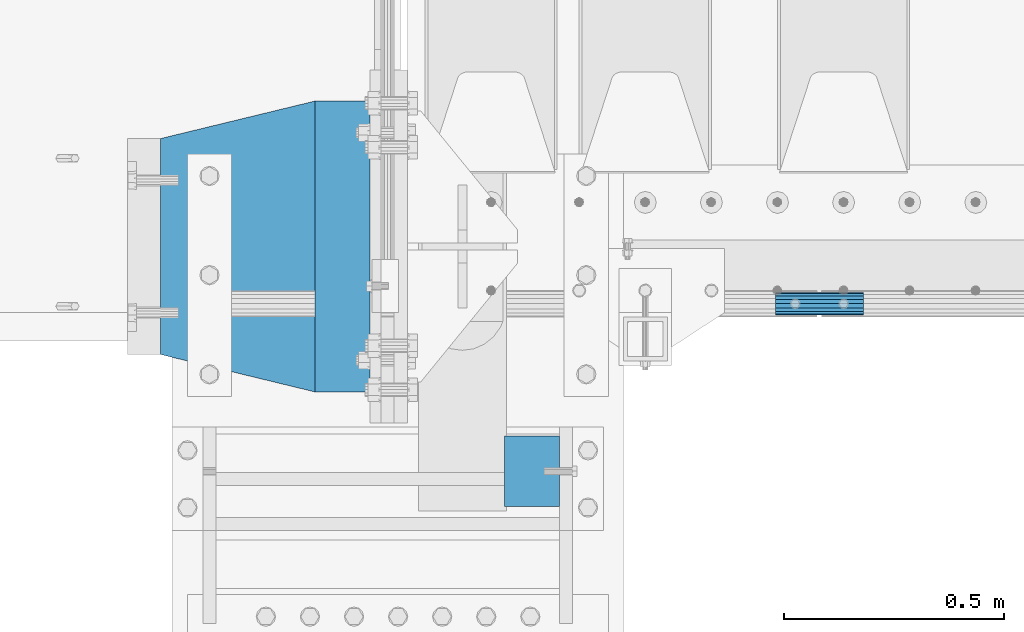
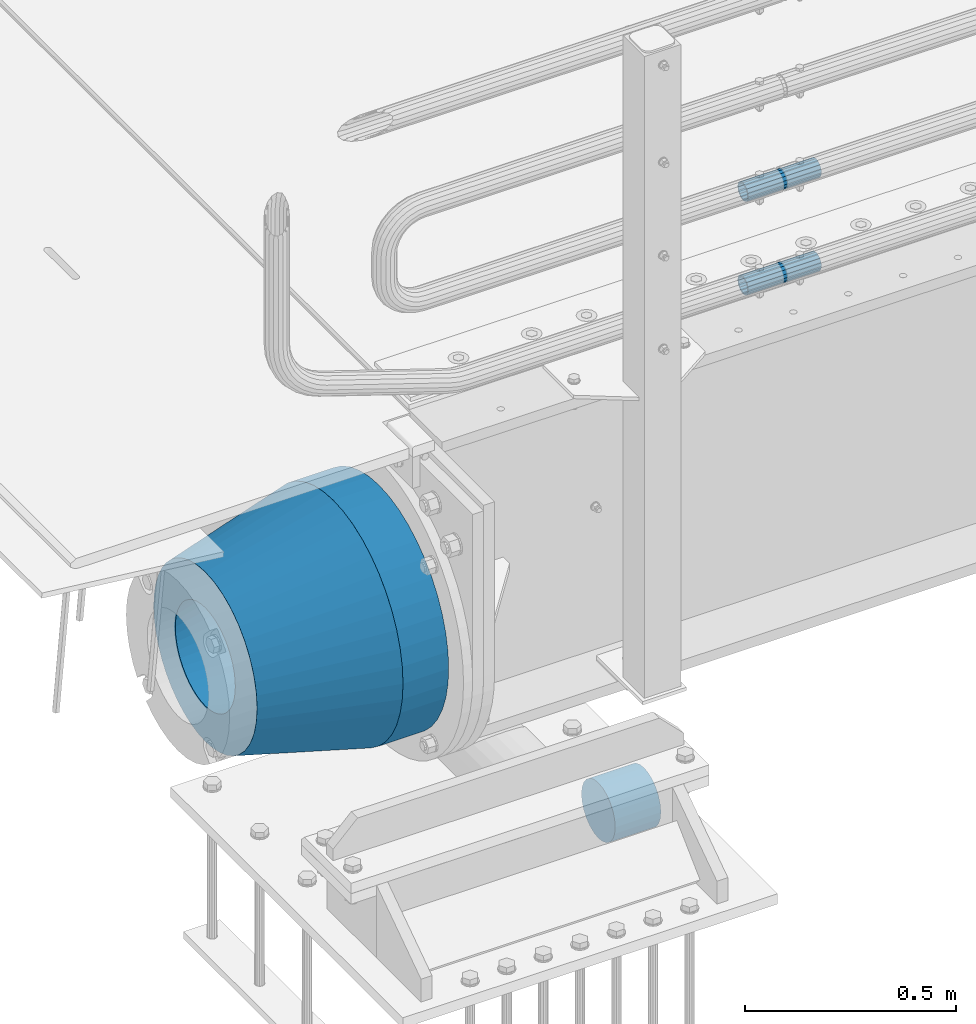
# One storey, part 131 of 240: 5 beams.
"""IFC2X3 building model written with IfcOpenShell, lengths in millimetres."""

from ifc_helpers import new_model, si_unit, frame, origin_with_axes, place, context, subcontext, project, spatial, faceted_brep, material, type_object, element, save


model = new_model("IFC2X3")

# Units and contexts
model_context = context("Model", 3, precision=1e-05, world=origin_with_axes())
body_context = subcontext(model_context, "Body", "Model", "MODEL_VIEW")
ifc_project = project(units=[si_unit("LENGTHUNIT", "METRE", prefix="MILLI"), si_unit("AREAUNIT", "SQUARE_METRE"), si_unit("VOLUMEUNIT", "CUBIC_METRE"), si_unit("MASSUNIT", "GRAM", prefix="KILO"), si_unit("TIMEUNIT", "SECOND"), si_unit("PLANEANGLEUNIT", "RADIAN"), si_unit("SOLIDANGLEUNIT", "STERADIAN"), si_unit("THERMODYNAMICTEMPERATUREUNIT", "DEGREE_CELSIUS"), si_unit("LUMINOUSINTENSITYUNIT", "LUMEN")], contexts=[model_context])

# Site, building, storey
site_placement = place(None, origin_with_axes())
site = spatial("IfcSite", under=ifc_project, at=site_placement, CompositionType="ELEMENT")
building_placement = place(site_placement, origin_with_axes())
building = spatial("IfcBuilding", under=site, at=building_placement, Name="Standard", CompositionType="ELEMENT")
storey_placement = place(building_placement, origin_with_axes())
storey = spatial("IfcBuildingStorey", under=building, at=storey_placement, Name="Undefined", CompositionType="ELEMENT", Elevation=0.0)

# Beams
ifc_material_1 = material()
beam_type_1 = type_object("IfcBeamType", PredefinedType="NOTDEFINED")
beam_1_placement = place(storey_placement, frame((42680.0000000009, 23490.000000001, -923.000000000004), z_axis=(0.0, 0.0, -1.0), x_axis=(1.0, 0.0, 0.0)))
element("IfcBeam", 1, at=beam_1_placement, inside=storey, type_object=beam_type_1, material=ifc_material_1, context=body_context, shape_type="Brep", body=[
    faceted_brep([(0.0, -80.0, 0.0), (0.0, -77.2740661031239, -20.7055236082017), (125.0, -77.2740661031239, -20.7055236082017), (125.0, -80.0, 0.0), (0.0, -69.2820323027554, -40.0), (125.0, -69.2820323027554, -40.0), (0.0, -56.5685424949224, -56.5685424949238), (125.0, -56.5685424949224, -56.5685424949238), (0.0, -40.0, -69.2820323027552), (125.0, -40.0, -69.2820323027552), (0.0, -20.7055236082015, -77.2740661031255), (125.0, -20.7055236082015, -77.2740661031255), (0.0, 0.0, -80.0), (125.0, 0.0, -80.0), (0.0, 20.7055236082015, -77.2740661031255), (125.0, 20.7055236082015, -77.2740661031255), (0.0, 40.0, -69.2820323027551), (125.0, 40.0, -69.2820323027551), (0.0, 56.5685424949224, -56.5685424949238), (125.0, 56.5685424949224, -56.5685424949238), (0.0, 69.2820323027554, -40.0), (125.0, 69.2820323027554, -40.0), (0.0, 77.2740661031239, -20.7055236082016), (125.0, 77.2740661031239, -20.7055236082016), (0.0, 80.0, 0.0), (125.0, 80.0, 0.0), (0.0, 77.2740661031239, 20.7055236082017), (125.0, 77.2740661031239, 20.7055236082017), (0.0, 69.2820323027554, 40.0), (125.0, 69.2820323027554, 40.0), (0.0, 56.5685424949224, 56.5685424949238), (125.0, 56.5685424949224, 56.5685424949238), (0.0, 40.0, 69.2820323027551), (125.0, 40.0, 69.2820323027551), (0.0, 20.7055236082015, 77.2740661031255), (125.0, 20.7055236082015, 77.2740661031255), (0.0, 0.0, 80.0), (125.0, 0.0, 80.0), (0.0, -20.7055236082015, 77.2740661031255), (125.0, -20.7055236082015, 77.2740661031255), (0.0, -40.0, 69.2820323027551), (125.0, -40.0, 69.2820323027551), (0.0, -56.5685424949224, 56.5685424949238), (125.0, -56.5685424949224, 56.5685424949238), (0.0, -69.2820323027554, 40.0), (125.0, -69.2820323027554, 40.0), (0.0, -77.2740661031239, 20.7055236082017), (125.0, -77.2740661031239, 20.7055236082017)], [[[0, 1, 2, 3]], [[1, 4, 5, 2]], [[4, 6, 7, 5]], [[6, 8, 9, 7]], [[8, 10, 11, 9]], [[10, 12, 13, 11]], [[12, 14, 15, 13]], [[14, 16, 17, 15]], [[16, 18, 19, 17]], [[18, 20, 21, 19]], [[20, 22, 23, 21]], [[22, 24, 25, 23]], [[24, 26, 27, 25]], [[26, 28, 29, 27]], [[28, 30, 31, 29]], [[30, 32, 33, 31]], [[32, 34, 35, 33]], [[34, 36, 37, 35]], [[36, 38, 39, 37]], [[38, 40, 41, 39]], [[40, 42, 43, 41]], [[42, 44, 45, 43]], [[44, 46, 47, 45]], [[46, 0, 3, 47]], [[5, 7, 9, 11, 13, 15, 17, 19, 21, 23, 25, 27, 29, 31, 33, 35, 37, 39, 41, 43, 45, 47, 3, 2]], [[46, 44, 42, 40, 38, 36, 34, 32, 30, 28, 26, 24, 22, 20, 18, 16, 14, 12, 10, 8, 6, 4, 1, 0]]]),
])
ifc_material_2 = material()
beam_type_2 = type_object("IfcBeamType", PredefinedType="NOTDEFINED")
beam_2_placement = place(storey_placement, frame((43294.9975029999, 23870.1500000004, 149.849999999747), z_axis=(0.0, 0.0, 1.0), x_axis=(1.0, 0.0, 0.0)))
element("IfcBeam", 2, at=beam_2_placement, inside=storey, type_object=beam_type_2, material=ifc_material_2, context=body_context, shape_type="Brep", body=[
    faceted_brep([(0.0, -21.9000000000015, 0.0), (0.0, -20.232961761998, 8.38076716879547), (200.0, -20.232961761998, 8.38076716879547), (200.0, -21.9000000000015, 0.0), (0.0, -15.4856385079838, 15.4856385079854), (200.0, -15.4856385079838, 15.4856385079854), (0.0, -8.38076716879732, 20.2329617619972), (200.0, -8.38076716879732, 20.2329617619972), (0.0, 0.0, 21.9), (200.0, 0.0, 21.9), (0.0, 8.38076716879732, 20.2329617619972), (200.0, 8.38076716879732, 20.2329617619972), (0.0, 15.4856385079838, 15.4856385079854), (200.0, 15.4856385079838, 15.4856385079854), (0.0, 20.232961761998, 8.38076716879547), (200.0, 20.232961761998, 8.38076716879547), (0.0, 21.9000000000015, 0.0), (200.0, 21.9000000000015, 0.0), (0.0, 20.232961761998, -8.38076716879547), (200.0, 20.232961761998, -8.38076716879547), (0.0, 15.4856385079838, -15.4856385079854), (200.0, 15.4856385079838, -15.4856385079854), (0.0, 8.38076716879732, -20.2329617619972), (200.0, 8.38076716879732, -20.2329617619972), (0.0, 0.0, -21.9), (200.0, 0.0, -21.9), (0.0, -8.38076716879732, -20.2329617619972), (200.0, -8.38076716879732, -20.2329617619972), (0.0, -15.4856385079838, -15.4856385079854), (200.0, -15.4856385079838, -15.4856385079854), (0.0, -20.232961761998, -8.38076716879547), (200.0, -20.232961761998, -8.38076716879547), (0.0, -25.5, 0.0), (0.0, -23.5589280790373, -9.7584275253098), (200.0, -23.5589280790373, -9.7584275253098), (200.0, -25.5, 0.0), (0.0, -18.0312229202536, -18.031222920257), (200.0, -18.0312229202536, -18.031222920257), (0.0, -9.75842752531025, -23.5589280790378), (200.0, -9.75842752531025, -23.5589280790378), (0.0, 0.0, -25.5), (200.0, 0.0, -25.5), (0.0, 9.75842752531025, -23.5589280790378), (200.0, 9.75842752531025, -23.5589280790378), (0.0, 18.0312229202536, -18.031222920257), (200.0, 18.0312229202536, -18.031222920257), (0.0, 23.5589280790373, -9.7584275253098), (200.0, 23.5589280790373, -9.7584275253098), (0.0, 25.5, 0.0), (200.0, 25.5, 0.0), (0.0, 23.5589280790373, 9.7584275253098), (200.0, 23.5589280790373, 9.7584275253098), (0.0, 18.0312229202536, 18.031222920257), (200.0, 18.0312229202536, 18.031222920257), (0.0, 9.75842752531025, 23.5589280790378), (200.0, 9.75842752531025, 23.5589280790378), (0.0, 0.0, 25.5), (200.0, 0.0, 25.5), (0.0, -9.75842752531025, 23.5589280790378), (200.0, -9.75842752531025, 23.5589280790378), (0.0, -18.0312229202536, 18.031222920257), (200.0, -18.0312229202536, 18.031222920257), (0.0, -23.5589280790373, 9.7584275253098), (200.0, -23.5589280790373, 9.7584275253098)], [[[0, 1, 2, 3]], [[1, 4, 5, 2]], [[4, 6, 7, 5]], [[6, 8, 9, 7]], [[8, 10, 11, 9]], [[10, 12, 13, 11]], [[12, 14, 15, 13]], [[14, 16, 17, 15]], [[16, 18, 19, 17]], [[18, 20, 21, 19]], [[20, 22, 23, 21]], [[22, 24, 25, 23]], [[24, 26, 27, 25]], [[26, 28, 29, 27]], [[28, 30, 31, 29]], [[30, 0, 3, 31]], [[32, 33, 34, 35]], [[33, 36, 37, 34]], [[36, 38, 39, 37]], [[38, 40, 41, 39]], [[40, 42, 43, 41]], [[42, 44, 45, 43]], [[44, 46, 47, 45]], [[46, 48, 49, 47]], [[48, 50, 51, 49]], [[50, 52, 53, 51]], [[52, 54, 55, 53]], [[54, 56, 57, 55]], [[56, 58, 59, 57]], [[58, 60, 61, 59]], [[60, 62, 63, 61]], [[62, 32, 35, 63]], [[37, 39, 41, 43, 45, 47, 49, 51, 53, 55, 57, 59, 61, 63, 35, 34], [5, 7, 9, 11, 13, 15, 17, 19, 21, 23, 25, 27, 29, 31, 3, 2]], [[62, 60, 58, 56, 54, 52, 50, 48, 46, 44, 42, 40, 38, 36, 33, 32], [30, 28, 26, 24, 22, 20, 18, 16, 14, 12, 10, 8, 6, 4, 1, 0]]]),
])
beam_3_placement = place(storey_placement, frame((43294.9975029999, 23870.1500000004, 420.149999999747), z_axis=(0.0, 0.0, 1.0), x_axis=(1.0, 0.0, 0.0)))
element("IfcBeam", 3, at=beam_3_placement, inside=storey, type_object=beam_type_2, material=ifc_material_2, context=body_context, shape_type="Brep", body=[
    faceted_brep([(0.0, -21.9000000000015, 0.0), (0.0, -20.232961761998, 8.38076716879547), (200.0, -20.232961761998, 8.38076716879547), (200.0, -21.9000000000015, 0.0), (0.0, -15.4856385079838, 15.4856385079854), (200.0, -15.4856385079838, 15.4856385079854), (0.0, -8.38076716879732, 20.2329617619972), (200.0, -8.38076716879732, 20.2329617619972), (0.0, 0.0, 21.9), (200.0, 0.0, 21.9), (0.0, 8.38076716879732, 20.2329617619972), (200.0, 8.38076716879732, 20.2329617619972), (0.0, 15.4856385079838, 15.4856385079854), (200.0, 15.4856385079838, 15.4856385079854), (0.0, 20.232961761998, 8.38076716879547), (200.0, 20.232961761998, 8.38076716879547), (0.0, 21.9000000000015, 0.0), (200.0, 21.9000000000015, 0.0), (0.0, 20.232961761998, -8.38076716879547), (200.0, 20.232961761998, -8.38076716879547), (0.0, 15.4856385079838, -15.4856385079854), (200.0, 15.4856385079838, -15.4856385079854), (0.0, 8.38076716879732, -20.2329617619972), (200.0, 8.38076716879732, -20.2329617619972), (0.0, 0.0, -21.9), (200.0, 0.0, -21.9), (0.0, -8.38076716879732, -20.2329617619972), (200.0, -8.38076716879732, -20.2329617619972), (0.0, -15.4856385079838, -15.4856385079854), (200.0, -15.4856385079838, -15.4856385079854), (0.0, -20.232961761998, -8.38076716879547), (200.0, -20.232961761998, -8.38076716879547), (0.0, -25.5, 0.0), (0.0, -23.5589280790373, -9.7584275253098), (200.0, -23.5589280790373, -9.7584275253098), (200.0, -25.5, 0.0), (0.0, -18.0312229202536, -18.031222920257), (200.0, -18.0312229202536, -18.031222920257), (0.0, -9.75842752531025, -23.5589280790378), (200.0, -9.75842752531025, -23.5589280790378), (0.0, 0.0, -25.5), (200.0, 0.0, -25.5), (0.0, 9.75842752531025, -23.5589280790378), (200.0, 9.75842752531025, -23.5589280790378), (0.0, 18.0312229202536, -18.031222920257), (200.0, 18.0312229202536, -18.031222920257), (0.0, 23.5589280790373, -9.7584275253098), (200.0, 23.5589280790373, -9.7584275253098), (0.0, 25.5, 0.0), (200.0, 25.5, 0.0), (0.0, 23.5589280790373, 9.7584275253098), (200.0, 23.5589280790373, 9.7584275253098), (0.0, 18.0312229202536, 18.031222920257), (200.0, 18.0312229202536, 18.031222920257), (0.0, 9.75842752531025, 23.5589280790378), (200.0, 9.75842752531025, 23.5589280790378), (0.0, 0.0, 25.5), (200.0, 0.0, 25.5), (0.0, -9.75842752531025, 23.5589280790378), (200.0, -9.75842752531025, 23.5589280790378), (0.0, -18.0312229202536, 18.031222920257), (200.0, -18.0312229202536, 18.031222920257), (0.0, -23.5589280790373, 9.7584275253098), (200.0, -23.5589280790373, 9.7584275253098)], [[[0, 1, 2, 3]], [[1, 4, 5, 2]], [[4, 6, 7, 5]], [[6, 8, 9, 7]], [[8, 10, 11, 9]], [[10, 12, 13, 11]], [[12, 14, 15, 13]], [[14, 16, 17, 15]], [[16, 18, 19, 17]], [[18, 20, 21, 19]], [[20, 22, 23, 21]], [[22, 24, 25, 23]], [[24, 26, 27, 25]], [[26, 28, 29, 27]], [[28, 30, 31, 29]], [[30, 0, 3, 31]], [[32, 33, 34, 35]], [[33, 36, 37, 34]], [[36, 38, 39, 37]], [[38, 40, 41, 39]], [[40, 42, 43, 41]], [[42, 44, 45, 43]], [[44, 46, 47, 45]], [[46, 48, 49, 47]], [[48, 50, 51, 49]], [[50, 52, 53, 51]], [[52, 54, 55, 53]], [[54, 56, 57, 55]], [[56, 58, 59, 57]], [[58, 60, 61, 59]], [[60, 62, 63, 61]], [[62, 32, 35, 63]], [[37, 39, 41, 43, 45, 47, 49, 51, 53, 55, 57, 59, 61, 63, 35, 34], [5, 7, 9, 11, 13, 15, 17, 19, 21, 23, 25, 27, 29, 31, 3, 2]], [[62, 60, 58, 56, 54, 52, 50, 48, 46, 44, 42, 40, 38, 36, 33, 32], [30, 28, 26, 24, 22, 20, 18, 16, 14, 12, 10, 8, 6, 4, 1, 0]]]),
])
ifc_material_3 = material(Name="STEEL/S355N")
beam_type_3 = type_object("IfcBeamType", PredefinedType="NOTDEFINED")
beam_4_placement = place(storey_placement, frame((42375.0, 24000.0, -515.0), z_axis=(0.0, 0.0, 1.0), x_axis=(-1.0, 0.0, 0.0)))
element("IfcBeam", 4, at=beam_4_placement, inside=storey, type_object=beam_type_3, material=ifc_material_3, context=body_context, shape_type="Brep", body=[
    faceted_brep([(0.0, -215.0, 0.0), (0.0, -212.811610004399, 30.5976902287563), (125.0, -212.811610004399, 30.5976902287563), (125.0, -215.0, 0.0), (0.0, -206.290989327113, 60.5724997209074), (125.0, -206.290989327113, 60.5724997209074), (0.0, -195.570879001221, 89.3142277954056), (125.0, -195.570879001221, 89.3142277954056), (0.0, -180.869509558703, 116.237775752953), (125.0, -180.869509558703, 116.237775752953), (0.0, -162.486158486165, 140.795057798236), (125.0, -162.486158486165, 140.795057798236), (0.0, -140.795057798234, 162.486158486165), (125.0, -140.795057798234, 162.486158486165), (0.0, -116.237775752954, 180.869509558704), (125.0, -116.237775752954, 180.869509558704), (0.0, -89.314227795403, 195.570879001222), (125.0, -89.314227795403, 195.570879001222), (0.0, -60.5724997209109, 206.290989327117), (125.0, -60.5724997209109, 206.290989327117), (0.0, -30.5976902287584, 212.811610004401), (125.0, -30.5976902287584, 212.811610004401), (0.0, 0.0, 215.0), (125.0, 0.0, 215.0), (0.0, 30.5976902287584, 212.811610004401), (125.0, 30.5976902287584, 212.811610004401), (0.0, 60.5724997209109, 206.290989327117), (125.0, 60.5724997209109, 206.290989327117), (0.0, 89.314227795403, 195.570879001221), (125.0, 89.314227795403, 195.570879001221), (0.0, 116.237775752954, 180.869509558704), (125.0, 116.237775752954, 180.869509558704), (0.0, 140.795057798234, 162.486158486165), (125.0, 140.795057798234, 162.486158486165), (0.0, 162.486158486165, 140.795057798236), (125.0, 162.486158486165, 140.795057798236), (0.0, 180.869509558703, 116.237775752953), (125.0, 180.869509558703, 116.237775752953), (0.0, 195.570879001221, 89.3142277954056), (125.0, 195.570879001221, 89.3142277954056), (0.0, 206.290989327113, 60.5724997209073), (125.0, 206.290989327113, 60.5724997209073), (0.0, 212.811610004399, 30.5976902287563), (125.0, 212.811610004399, 30.5976902287563), (0.0, 215.0, 0.0), (125.0, 215.0, 0.0), (0.0, 212.811610004399, -30.5976902287563), (125.0, 212.811610004399, -30.5976902287563), (0.0, 206.290989327113, -60.5724997209073), (125.0, 206.290989327113, -60.5724997209073), (0.0, 195.570879001221, -89.3142277954056), (125.0, 195.570879001221, -89.3142277954056), (0.0, 180.869509558703, -116.237775752954), (125.0, 180.869509558703, -116.237775752954), (0.0, 162.486158486165, -140.795057798236), (125.0, 162.486158486165, -140.795057798236), (0.0, 140.795057798234, -162.486158486166), (125.0, 140.795057798234, -162.486158486166), (0.0, 116.237775752954, -180.869509558704), (125.0, 116.237775752954, -180.869509558704), (0.0, 89.314227795403, -195.570879001221), (125.0, 89.314227795403, -195.570879001221), (0.0, 60.5724997209109, -206.290989327117), (125.0, 60.5724997209109, -206.290989327117), (0.0, 30.5976902287584, -212.811610004401), (125.0, 30.5976902287584, -212.811610004401), (0.0, 0.0, -215.0), (125.0, 0.0, -215.0), (0.0, -30.5976902287584, -212.811610004401), (125.0, -30.5976902287584, -212.811610004401), (0.0, -60.5724997209109, -206.290989327117), (125.0, -60.5724997209109, -206.290989327117), (0.0, -89.314227795403, -195.570879001221), (125.0, -89.314227795403, -195.570879001221), (0.0, -116.237775752954, -180.869509558704), (125.0, -116.237775752954, -180.869509558704), (0.0, -140.795057798234, -162.486158486166), (125.0, -140.795057798234, -162.486158486166), (0.0, -162.486158486165, -140.795057798236), (125.0, -162.486158486165, -140.795057798236), (0.0, -180.869509558703, -116.237775752953), (125.0, -180.869509558703, -116.237775752953), (0.0, -195.570879001221, -89.3142277954056), (125.0, -195.570879001221, -89.3142277954056), (0.0, -206.290989327113, -60.5724997209073), (125.0, -206.290989327113, -60.5724997209073), (0.0, -212.811610004399, -30.5976902287563), (125.0, -212.811610004399, -30.5976902287563), (0.0, -330.0, 0.0), (0.0, -326.641075820706, -46.9638966301842), (125.0, -326.641075820706, -46.9638966301842), (125.0, -330.0, 0.0), (0.0, -316.632681292787, -92.9717437576718), (125.0, -316.632681292787, -92.9717437576718), (0.0, -300.178558466992, -137.086954290623), (125.0, -300.178558466992, -137.086954290623), (0.0, -277.613665834288, -178.411469760347), (125.0, -277.613665834288, -178.411469760347), (0.0, -249.397359536903, -216.104042201944), (125.0, -249.397359536903, -216.104042201944), (0.0, -216.104042201943, -249.397359536905), (125.0, -216.104042201943, -249.397359536905), (0.0, -178.411469760344, -277.61366583429), (125.0, -178.411469760344, -277.61366583429), (0.0, -137.086954290622, -300.178558466991), (125.0, -137.086954290622, -300.178558466991), (0.0, -92.9717437576692, -316.632681292784), (125.0, -92.9717437576692, -316.632681292784), (0.0, -46.9638966301864, -326.641075820708), (125.0, -46.9638966301864, -326.641075820708), (0.0, 0.0, -330.0), (125.0, 0.0, -330.0), (0.0, 46.9638966301864, -326.641075820708), (125.0, 46.9638966301864, -326.641075820708), (0.0, 92.9717437576692, -316.632681292784), (125.0, 92.9717437576692, -316.632681292784), (0.0, 137.086954290622, -300.178558466991), (125.0, 137.086954290622, -300.178558466991), (0.0, 178.411469760344, -277.61366583429), (125.0, 178.411469760344, -277.61366583429), (0.0, 216.104042201943, -249.397359536905), (125.0, 216.104042201943, -249.397359536905), (0.0, 249.397359536903, -216.104042201944), (125.0, 249.397359536903, -216.104042201944), (0.0, 277.613665834288, -178.411469760347), (125.0, 277.613665834288, -178.411469760347), (0.0, 300.178558466992, -137.086954290623), (125.0, 300.178558466992, -137.086954290623), (0.0, 316.632681292787, -92.9717437576717), (125.0, 316.632681292787, -92.9717437576717), (0.0, 326.641075820706, -46.9638966301841), (125.0, 326.641075820706, -46.9638966301841), (0.0, 330.0, 0.0), (125.0, 330.0, 0.0), (0.0, 326.641075820706, 46.9638966301841), (125.0, 326.641075820706, 46.9638966301841), (0.0, 316.632681292787, 92.9717437576718), (125.0, 316.632681292787, 92.9717437576718), (0.0, 300.178558466992, 137.086954290622), (125.0, 300.178558466992, 137.086954290622), (0.0, 277.613665834288, 178.411469760347), (125.0, 277.613665834288, 178.411469760347), (0.0, 249.397359536903, 216.104042201944), (125.0, 249.397359536903, 216.104042201944), (0.0, 216.104042201943, 249.397359536905), (125.0, 216.104042201943, 249.397359536905), (0.0, 178.411469760344, 277.61366583429), (125.0, 178.411469760344, 277.61366583429), (0.0, 137.086954290622, 300.178558466991), (125.0, 137.086954290622, 300.178558466991), (0.0, 92.9717437576692, 316.632681292784), (125.0, 92.9717437576692, 316.632681292784), (0.0, 46.9638966301864, 326.641075820708), (125.0, 46.9638966301864, 326.641075820708), (0.0, 0.0, 330.0), (125.0, 0.0, 330.0), (0.0, -46.9638966301864, 326.641075820708), (125.0, -46.9638966301864, 326.641075820708), (0.0, -92.9717437576692, 316.632681292784), (125.0, -92.9717437576692, 316.632681292784), (0.0, -137.086954290622, 300.178558466991), (125.0, -137.086954290622, 300.178558466991), (0.0, -178.411469760344, 277.61366583429), (125.0, -178.411469760344, 277.61366583429), (0.0, -216.104042201943, 249.397359536905), (125.0, -216.104042201943, 249.397359536905), (0.0, -249.397359536903, 216.104042201944), (125.0, -249.397359536903, 216.104042201944), (0.0, -277.613665834288, 178.411469760347), (125.0, -277.613665834288, 178.411469760347), (0.0, -300.178558466992, 137.086954290623), (125.0, -300.178558466992, 137.086954290623), (0.0, -316.632681292787, 92.9717437576718), (125.0, -316.632681292787, 92.9717437576718), (0.0, -326.641075820706, 46.9638966301841), (125.0, -326.641075820706, 46.9638966301841)], [[[0, 1, 2, 3]], [[1, 4, 5, 2]], [[4, 6, 7, 5]], [[6, 8, 9, 7]], [[8, 10, 11, 9]], [[10, 12, 13, 11]], [[12, 14, 15, 13]], [[14, 16, 17, 15]], [[16, 18, 19, 17]], [[18, 20, 21, 19]], [[20, 22, 23, 21]], [[22, 24, 25, 23]], [[24, 26, 27, 25]], [[26, 28, 29, 27]], [[28, 30, 31, 29]], [[30, 32, 33, 31]], [[32, 34, 35, 33]], [[34, 36, 37, 35]], [[36, 38, 39, 37]], [[38, 40, 41, 39]], [[40, 42, 43, 41]], [[42, 44, 45, 43]], [[44, 46, 47, 45]], [[46, 48, 49, 47]], [[48, 50, 51, 49]], [[50, 52, 53, 51]], [[52, 54, 55, 53]], [[54, 56, 57, 55]], [[56, 58, 59, 57]], [[58, 60, 61, 59]], [[60, 62, 63, 61]], [[62, 64, 65, 63]], [[64, 66, 67, 65]], [[66, 68, 69, 67]], [[68, 70, 71, 69]], [[70, 72, 73, 71]], [[72, 74, 75, 73]], [[74, 76, 77, 75]], [[76, 78, 79, 77]], [[78, 80, 81, 79]], [[80, 82, 83, 81]], [[82, 84, 85, 83]], [[84, 86, 87, 85]], [[86, 0, 3, 87]], [[88, 89, 90, 91]], [[89, 92, 93, 90]], [[92, 94, 95, 93]], [[94, 96, 97, 95]], [[96, 98, 99, 97]], [[98, 100, 101, 99]], [[100, 102, 103, 101]], [[102, 104, 105, 103]], [[104, 106, 107, 105]], [[106, 108, 109, 107]], [[108, 110, 111, 109]], [[110, 112, 113, 111]], [[112, 114, 115, 113]], [[114, 116, 117, 115]], [[116, 118, 119, 117]], [[118, 120, 121, 119]], [[120, 122, 123, 121]], [[122, 124, 125, 123]], [[124, 126, 127, 125]], [[126, 128, 129, 127]], [[128, 130, 131, 129]], [[130, 132, 133, 131]], [[132, 134, 135, 133]], [[134, 136, 137, 135]], [[136, 138, 139, 137]], [[138, 140, 141, 139]], [[140, 142, 143, 141]], [[142, 144, 145, 143]], [[144, 146, 147, 145]], [[146, 148, 149, 147]], [[148, 150, 151, 149]], [[150, 152, 153, 151]], [[152, 154, 155, 153]], [[154, 156, 157, 155]], [[156, 158, 159, 157]], [[158, 160, 161, 159]], [[160, 162, 163, 161]], [[162, 164, 165, 163]], [[164, 166, 167, 165]], [[166, 168, 169, 167]], [[168, 170, 171, 169]], [[170, 172, 173, 171]], [[172, 174, 175, 173]], [[174, 88, 91, 175]], [[93, 95, 97, 99, 101, 103, 105, 107, 109, 111, 113, 115, 117, 119, 121, 123, 125, 127, 129, 131, 133, 135, 137, 139, 141, 143, 145, 147, 149, 151, 153, 155, 157, 159, 161, 163, 165, 167, 169, 171, 173, 175, 91, 90], [5, 7, 9, 11, 13, 15, 17, 19, 21, 23, 25, 27, 29, 31, 33, 35, 37, 39, 41, 43, 45, 47, 49, 51, 53, 55, 57, 59, 61, 63, 65, 67, 69, 71, 73, 75, 77, 79, 81, 83, 85, 87, 3, 2]], [[174, 172, 170, 168, 166, 164, 162, 160, 158, 156, 154, 152, 150, 148, 146, 144, 142, 140, 138, 136, 134, 132, 130, 128, 126, 124, 122, 120, 118, 116, 114, 112, 110, 108, 106, 104, 102, 100, 98, 96, 94, 92, 89, 88], [86, 84, 82, 80, 78, 76, 74, 72, 70, 68, 66, 64, 62, 60, 58, 56, 54, 52, 50, 48, 46, 44, 42, 40, 38, 36, 34, 32, 30, 28, 26, 24, 22, 20, 18, 16, 14, 12, 10, 8, 6, 4, 1, 0]]]),
])
ifc_material_4 = material(Name="SCN-500-E2")
beam_type_4 = type_object("IfcBeamType", PredefinedType="NOTDEFINED")
beam_5_placement = place(storey_placement, frame((42250.0, 24000.0, -515.0), z_axis=(0.0, 0.0, 1.0), x_axis=(-1.0, 0.0, 0.0)))
element("IfcBeam", 5, at=beam_5_placement, inside=storey, type_object=beam_type_4, material=ifc_material_4, context=body_context, shape_type="Brep", body=[
    faceted_brep([(0.0, -330.0, 0.0), (0.0, -326.641075820706, -46.9638966301842), (350.0, -242.506253260828, -34.8671353769549), (350.0, -245.0, 0.0), (0.0, -316.632681292787, -92.9717437576718), (350.0, -235.075778535553, -69.0244764261503), (0.0, -300.178558466992, -137.086954290623), (350.0, -222.859838861856, -101.776678185462), (0.0, -277.613665834288, -178.411469760347), (350.0, -206.107115543637, -132.457000276621), (0.0, -249.397359536903, -216.104042201944), (350.0, -185.158645716794, -160.440879816595), (0.0, -216.104042201943, -249.397359536905), (350.0, -160.440879816597, -185.158645716793), (0.0, -178.411469760344, -277.61366583429), (350.0, -132.45700027662, -206.107115543639), (0.0, -137.086954290622, -300.178558466991), (350.0, -101.776678185459, -222.859838861857), (0.0, -92.9717437576692, -316.632681292784), (350.0, -69.0244764261515, -235.075778535552), (0.0, -46.9638966301864, -326.641075820708), (350.0, -34.8671353769532, -242.506253260829), (0.0, 0.0, -330.0), (350.0, 0.0, -245.0), (0.0, 46.9638966301864, -326.641075820708), (350.0, 34.8671353769532, -242.506253260829), (0.0, 92.9717437576692, -316.632681292784), (350.0, 69.0244764261515, -235.075778535552), (0.0, 137.086954290622, -300.178558466991), (350.0, 101.776678185459, -222.859838861857), (0.0, 178.411469760344, -277.61366583429), (350.0, 132.45700027662, -206.107115543639), (0.0, 216.104042201943, -249.397359536905), (350.0, 160.440879816597, -185.158645716793), (0.0, 249.397359536903, -216.104042201944), (350.0, 185.158645716794, -160.440879816595), (0.0, 277.613665834288, -178.411469760347), (350.0, 206.107115543637, -132.457000276621), (0.0, 300.178558466992, -137.086954290623), (350.0, 222.859838861856, -101.776678185462), (0.0, 316.632681292787, -92.9717437576717), (350.0, 235.075778535553, -69.0244764261502), (0.0, 326.641075820706, -46.9638966301841), (350.0, 242.506253260828, -34.8671353769548), (0.0, 330.0, 0.0), (350.0, 245.0, 0.0), (0.0, 326.641075820706, 46.9638966301841), (350.0, 242.506253260828, 34.8671353769549), (0.0, 316.632681292787, 92.9717437576718), (350.0, 235.075778535553, 69.0244764261503), (0.0, 300.178558466992, 137.086954290622), (350.0, 222.859838861856, 101.776678185462), (0.0, 277.613665834288, 178.411469760347), (350.0, 206.107115543637, 132.457000276621), (0.0, 249.397359536903, 216.104042201944), (350.0, 185.158645716794, 160.440879816595), (0.0, 216.104042201943, 249.397359536905), (350.0, 160.440879816597, 185.158645716793), (0.0, 178.411469760344, 277.61366583429), (350.0, 132.45700027662, 206.107115543639), (0.0, 137.086954290622, 300.178558466991), (350.0, 101.776678185459, 222.859838861857), (0.0, 92.9717437576692, 316.632681292784), (350.0, 69.0244764261515, 235.075778535552), (0.0, 46.9638966301864, 326.641075820708), (350.0, 34.8671353769532, 242.506253260829), (0.0, 0.0, 330.0), (350.0, 0.0, 245.0), (0.0, -46.9638966301864, 326.641075820708), (350.0, -34.8671353769532, 242.506253260829), (0.0, -92.9717437576692, 316.632681292784), (350.0, -69.0244764261515, 235.075778535552), (0.0, -137.086954290622, 300.178558466991), (350.0, -101.776678185459, 222.859838861857), (0.0, -178.411469760344, 277.61366583429), (350.0, -132.45700027662, 206.107115543639), (0.0, -216.104042201943, 249.397359536905), (350.0, -160.440879816597, 185.158645716793), (0.0, -249.397359536903, 216.104042201944), (350.0, -185.158645716794, 160.440879816595), (0.0, -277.613665834288, 178.411469760347), (350.0, -206.107115543637, 132.457000276621), (0.0, -300.178558466992, 137.086954290623), (350.0, -222.859838861856, 101.776678185462), (0.0, -316.632681292787, 92.9717437576718), (350.0, -235.075778535553, 69.0244764261503), (0.0, -326.641075820706, 46.9638966301841), (350.0, -242.506253260828, 34.8671353769549), (0.0, -227.093265923133, 0.0), (0.0, -224.781783917482, 32.3187414128026), (350.0, -140.646961357605, 20.2219801595734), (350.0, -142.093265923133, 0.0), (0.0, -217.894393008413, 63.9795664499945), (350.0, -136.337490251179, 40.032299118473), (0.0, -206.571300613236, 94.3379520160985), (350.0, -129.252581008099, 59.0276759109381), (0.0, -191.043012240007, 122.775888927343), (350.0, -119.536461949356, 76.8214194436173), (0.0, -171.625639060127, 148.714462796454), (350.0, -107.386925240011, 93.0513004111044), (0.0, -148.714462796452, 171.625639060125), (350.0, -93.0513004111053, 107.386925240013), (0.0, -122.775888927346, 191.043012240005), (350.0, -76.821419443615, 119.536461949355), (0.0, -94.3379520160961, 206.571300613232), (350.0, -59.0276759109402, 129.252581008098), (0.0, -63.9795664499979, 217.894393008413), (350.0, -40.032299118473, 136.337490251181), (0.0, -32.3187414128042, 224.781783917484), (350.0, -20.2219801595711, 140.646961357605), (0.0, 0.0, 227.093265923131), (350.0, 0.0, 142.093265923131), (0.0, 32.3187414128042, 224.781783917484), (350.0, 20.2219801595711, 140.646961357605), (0.0, 63.9795664499979, 217.894393008413), (350.0, 40.032299118473, 136.337490251181), (0.0, 94.3379520160961, 206.571300613232), (350.0, 59.0276759109402, 129.252581008098), (0.0, 122.775888927346, 191.043012240005), (350.0, 76.821419443615, 119.536461949355), (0.0, 148.714462796452, 171.625639060125), (350.0, 93.0513004111053, 107.386925240013), (0.0, 171.625639060127, 148.714462796454), (350.0, 107.386925240011, 93.0513004111044), (0.0, 191.043012240007, 122.775888927343), (350.0, 119.536461949356, 76.8214194436174), (0.0, 206.571300613236, 94.3379520160985), (350.0, 129.252581008099, 59.0276759109382), (0.0, 217.894393008413, 63.9795664499945), (350.0, 136.337490251179, 40.032299118473), (0.0, 224.781783917482, 32.3187414128025), (350.0, 140.646961357605, 20.2219801595733), (0.0, 227.093265923133, 0.0), (350.0, 142.093265923133, 0.0), (0.0, 224.781783917482, -32.3187414128026), (350.0, 140.646961357605, -20.2219801595734), (0.0, 217.894393008413, -63.9795664499945), (350.0, 136.337490251179, -40.032299118473), (0.0, 206.571300613236, -94.3379520160985), (350.0, 129.252581008099, -59.0276759109381), (0.0, 191.043012240007, -122.775888927343), (350.0, 119.536461949356, -76.8214194436174), (0.0, 171.625639060127, -148.714462796454), (350.0, 107.386925240011, -93.0513004111044), (0.0, 148.714462796452, -171.625639060125), (350.0, 93.0513004111053, -107.386925240013), (0.0, 122.775888927346, -191.043012240005), (350.0, 76.821419443615, -119.536461949355), (0.0, 94.3379520160961, -206.571300613232), (350.0, 59.0276759109402, -129.252581008098), (0.0, 63.9795664499979, -217.894393008413), (350.0, 40.032299118473, -136.337490251181), (0.0, 32.3187414128042, -224.781783917484), (350.0, 20.2219801595711, -140.646961357605), (0.0, 0.0, -227.093265923131), (350.0, 0.0, -142.093265923131), (0.0, -32.3187414128042, -224.781783917484), (350.0, -20.2219801595711, -140.646961357605), (0.0, -63.9795664499979, -217.894393008413), (350.0, -40.032299118473, -136.337490251181), (0.0, -94.3379520160961, -206.571300613232), (350.0, -59.0276759109402, -129.252581008098), (0.0, -122.775888927346, -191.043012240005), (350.0, -76.821419443615, -119.536461949355), (0.0, -148.714462796452, -171.625639060125), (350.0, -93.0513004111053, -107.386925240013), (0.0, -171.625639060127, -148.714462796454), (350.0, -107.386925240011, -93.0513004111044), (0.0, -191.043012240007, -122.775888927343), (350.0, -119.536461949356, -76.8214194436174), (0.0, -206.571300613236, -94.3379520160985), (350.0, -129.252581008099, -59.0276759109381), (0.0, -217.894393008413, -63.9795664499945), (350.0, -136.337490251179, -40.032299118473), (0.0, -224.781783917482, -32.3187414128026), (350.0, -140.646961357605, -20.2219801595734)], [[[0, 1, 2, 3]], [[1, 4, 5, 2]], [[4, 6, 7, 5]], [[6, 8, 9, 7]], [[8, 10, 11, 9]], [[10, 12, 13, 11]], [[12, 14, 15, 13]], [[14, 16, 17, 15]], [[16, 18, 19, 17]], [[18, 20, 21, 19]], [[20, 22, 23, 21]], [[22, 24, 25, 23]], [[24, 26, 27, 25]], [[26, 28, 29, 27]], [[28, 30, 31, 29]], [[30, 32, 33, 31]], [[32, 34, 35, 33]], [[34, 36, 37, 35]], [[36, 38, 39, 37]], [[38, 40, 41, 39]], [[40, 42, 43, 41]], [[42, 44, 45, 43]], [[44, 46, 47, 45]], [[46, 48, 49, 47]], [[48, 50, 51, 49]], [[50, 52, 53, 51]], [[52, 54, 55, 53]], [[54, 56, 57, 55]], [[56, 58, 59, 57]], [[58, 60, 61, 59]], [[60, 62, 63, 61]], [[62, 64, 65, 63]], [[64, 66, 67, 65]], [[66, 68, 69, 67]], [[68, 70, 71, 69]], [[70, 72, 73, 71]], [[72, 74, 75, 73]], [[74, 76, 77, 75]], [[76, 78, 79, 77]], [[78, 80, 81, 79]], [[80, 82, 83, 81]], [[82, 84, 85, 83]], [[84, 86, 87, 85]], [[86, 0, 3, 87]], [[88, 89, 90, 91]], [[89, 92, 93, 90]], [[92, 94, 95, 93]], [[94, 96, 97, 95]], [[96, 98, 99, 97]], [[98, 100, 101, 99]], [[100, 102, 103, 101]], [[102, 104, 105, 103]], [[104, 106, 107, 105]], [[106, 108, 109, 107]], [[108, 110, 111, 109]], [[110, 112, 113, 111]], [[112, 114, 115, 113]], [[114, 116, 117, 115]], [[116, 118, 119, 117]], [[118, 120, 121, 119]], [[120, 122, 123, 121]], [[122, 124, 125, 123]], [[124, 126, 127, 125]], [[126, 128, 129, 127]], [[128, 130, 131, 129]], [[130, 132, 133, 131]], [[132, 134, 135, 133]], [[134, 136, 137, 135]], [[136, 138, 139, 137]], [[138, 140, 141, 139]], [[140, 142, 143, 141]], [[142, 144, 145, 143]], [[144, 146, 147, 145]], [[146, 148, 149, 147]], [[148, 150, 151, 149]], [[150, 152, 153, 151]], [[152, 154, 155, 153]], [[154, 156, 157, 155]], [[156, 158, 159, 157]], [[158, 160, 161, 159]], [[160, 162, 163, 161]], [[162, 164, 165, 163]], [[164, 166, 167, 165]], [[166, 168, 169, 167]], [[168, 170, 171, 169]], [[170, 172, 173, 171]], [[172, 174, 175, 173]], [[174, 88, 91, 175]], [[5, 7, 9, 11, 13, 15, 17, 19, 21, 23, 25, 27, 29, 31, 33, 35, 37, 39, 41, 43, 45, 47, 49, 51, 53, 55, 57, 59, 61, 63, 65, 67, 69, 71, 73, 75, 77, 79, 81, 83, 85, 87, 3, 2], [93, 95, 97, 99, 101, 103, 105, 107, 109, 111, 113, 115, 117, 119, 121, 123, 125, 127, 129, 131, 133, 135, 137, 139, 141, 143, 145, 147, 149, 151, 153, 155, 157, 159, 161, 163, 165, 167, 169, 171, 173, 175, 91, 90]], [[86, 84, 82, 80, 78, 76, 74, 72, 70, 68, 66, 64, 62, 60, 58, 56, 54, 52, 50, 48, 46, 44, 42, 40, 38, 36, 34, 32, 30, 28, 26, 24, 22, 20, 18, 16, 14, 12, 10, 8, 6, 4, 1, 0], [174, 172, 170, 168, 166, 164, 162, 160, 158, 156, 154, 152, 150, 148, 146, 144, 142, 140, 138, 136, 134, 132, 130, 128, 126, 124, 122, 120, 118, 116, 114, 112, 110, 108, 106, 104, 102, 100, 98, 96, 94, 92, 89, 88]]]),
])

save(model, "model.ifc")
